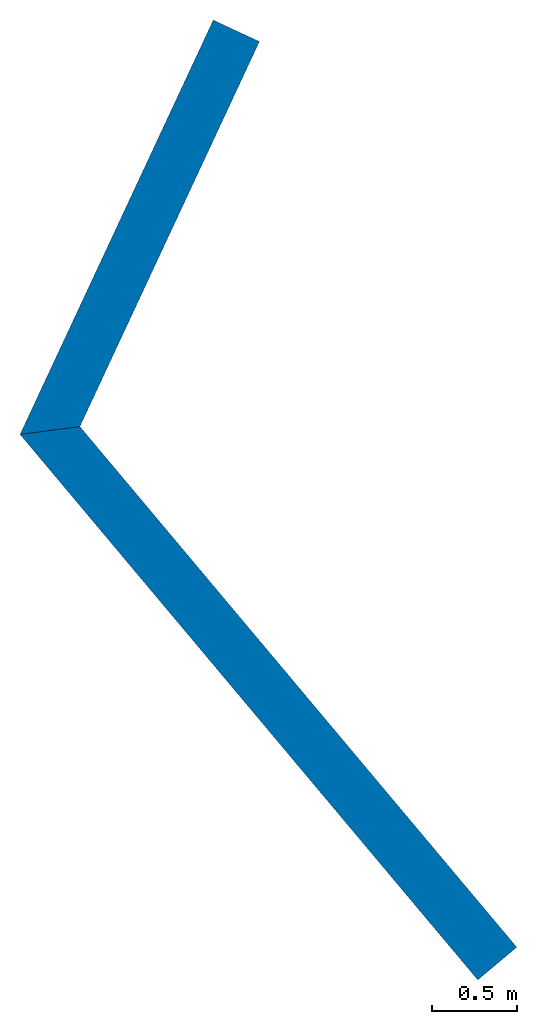
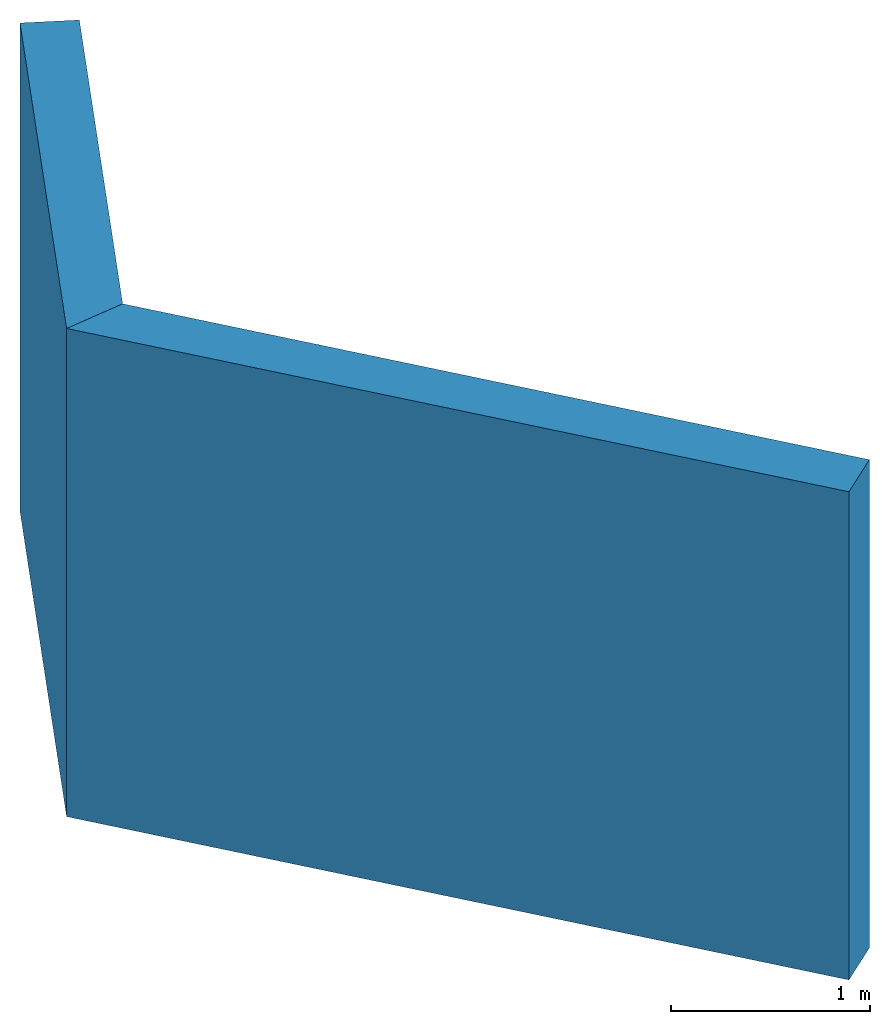
# One storey: 2 walls.
"""IFC4 building model written with IfcOpenShell, lengths in metres."""

from ifc_helpers import new_model, entity, si_unit, converted_unit, frame, origin_with_axes, origin_2d_with_axis, place, context, subcontext, project, spatial, indexed_curve, outline, extrude, clip, halfspace, material, layer, layer_set, layer_usage, type_object, element, save


model = new_model("IFC4")

# Units and contexts
model_context = context("Model", 3, precision=1e-05, world=origin_with_axes())
plan_context = context("Plan", 2, precision=1e-05, world=origin_2d_with_axis())
body_context = subcontext(model_context, "Body", "Model", "MODEL_VIEW")
ifc_project = project(units=[si_unit("VOLUMEUNIT", "CUBIC_METRE"), si_unit("LENGTHUNIT", "METRE"), converted_unit("PLANEANGLEUNIT", "degree", entity("IfcReal", 0.0174532925199433), si_unit("PLANEANGLEUNIT", "RADIAN"), dimensions=[0, 0, 0, 0, 0, 0, 0]), si_unit("AREAUNIT", "SQUARE_METRE")], contexts=[model_context, plan_context])

# Site, building, storey
site_placement = place(None, origin_with_axes())
site = spatial("IfcSite", under=ifc_project, at=site_placement)
building_placement = place(site_placement, origin_with_axes())
building = spatial("IfcBuilding", under=site, at=building_placement, Name="Building")
storey_placement = place(building_placement, origin_with_axes())
storey = spatial("IfcBuildingStorey", under=building, at=storey_placement, Name="Storey")

# Walls
ifc_material = material()
ifc_layer = layer(ifc_material, 0.300000011920929, ventilated=False)
ifc_layer_set = layer_set([ifc_layer])
ifc_layer_usage_1 = layer_usage(ifc_layer_set, "AXIS2", "POSITIVE", 0.0)
wall_type = type_object("IfcWallType", Name="30cm", PredefinedType="STANDARD", material=ifc_layer_set)
wall_1_placement = place(storey_placement, frame((-1.19707047939301, -3.28892421722412, 0.0), z_axis=(0.0, 0.0, 1.0), x_axis=(-0.642787463678256, 0.766044565634451, 0.0)))
element("IfcWall", 1, at=wall_1_placement, inside=storey, type_object=wall_type, material=ifc_layer_usage_1, Name="Wall", context=body_context, shape_type="Clipping", body=[
    clip(extrude(outline(indexed_curve([(0.0, 0.0), (0.0, 0.300000011920929), (4.33101323569157, 0.300000011920929), (4.33101323569157, 0.0), (0.0, 0.0)], self_intersect=False)), origin_with_axes(), (0.0, 0.0, 1.0), 3.0), halfspace(frame((4.00000047683716, -2.98023223876953e-07, 0.0), z_axis=(0.843392431735992, -0.537298202514648, 0.0), x_axis=(-0.537298161589986, -0.843392367496897, 0.0)), False)),
])
ifc_layer_usage_2 = layer_usage(ifc_layer_set, "AXIS2", "POSITIVE", 0.0)
wall_2_placement = place(storey_placement, frame((-3.90811252593994, -0.524745762348175, 0.0), z_axis=(0.0, 0.0, 1.0), x_axis=(0.422618232692772, 0.906307800581921, 0.0)))
element("IfcWall", 2, at=wall_2_placement, inside=storey, type_object=wall_type, material=ifc_layer_usage_2, Name="Wall", context=body_context, shape_type="Clipping", body=[
    clip(extrude(outline(indexed_curve([(0.0, 0.0), (0.0, 0.300000011920929), (2.83101268472663, 0.300000011920929), (2.83101268472663, 0.0), (0.0, 0.0)], self_intersect=False)), origin_with_axes(), (0.0, 0.0, 1.0), 3.0), halfspace(frame((0.331013560295105, 4.4703483581543e-08, 0.0), z_axis=(-0.843391120433807, -0.53730034828186, 0.0), x_axis=(-0.537300282115913, 0.843391016574258, 0.0)), False)),
])

save(model, "model.ifc")
